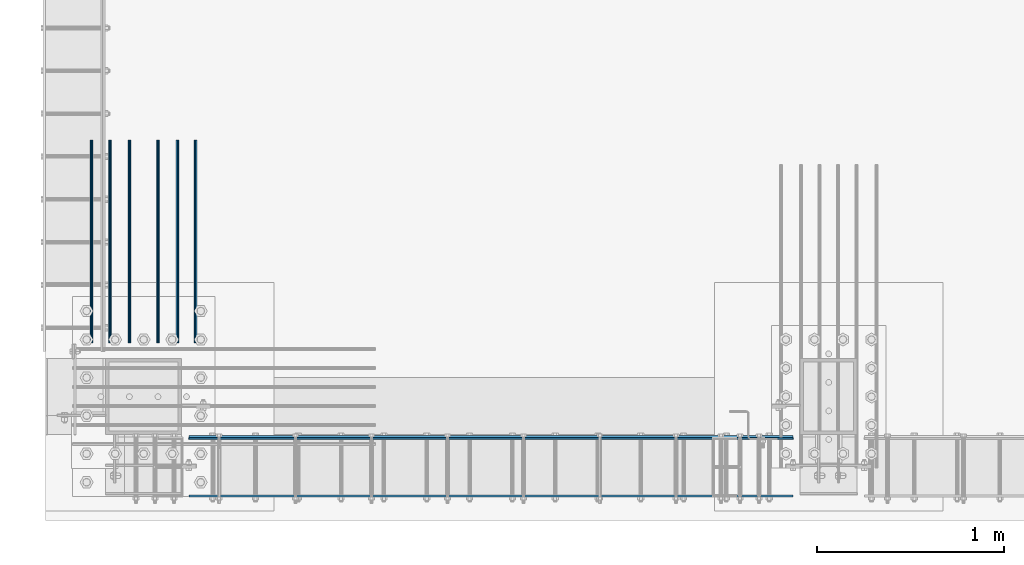
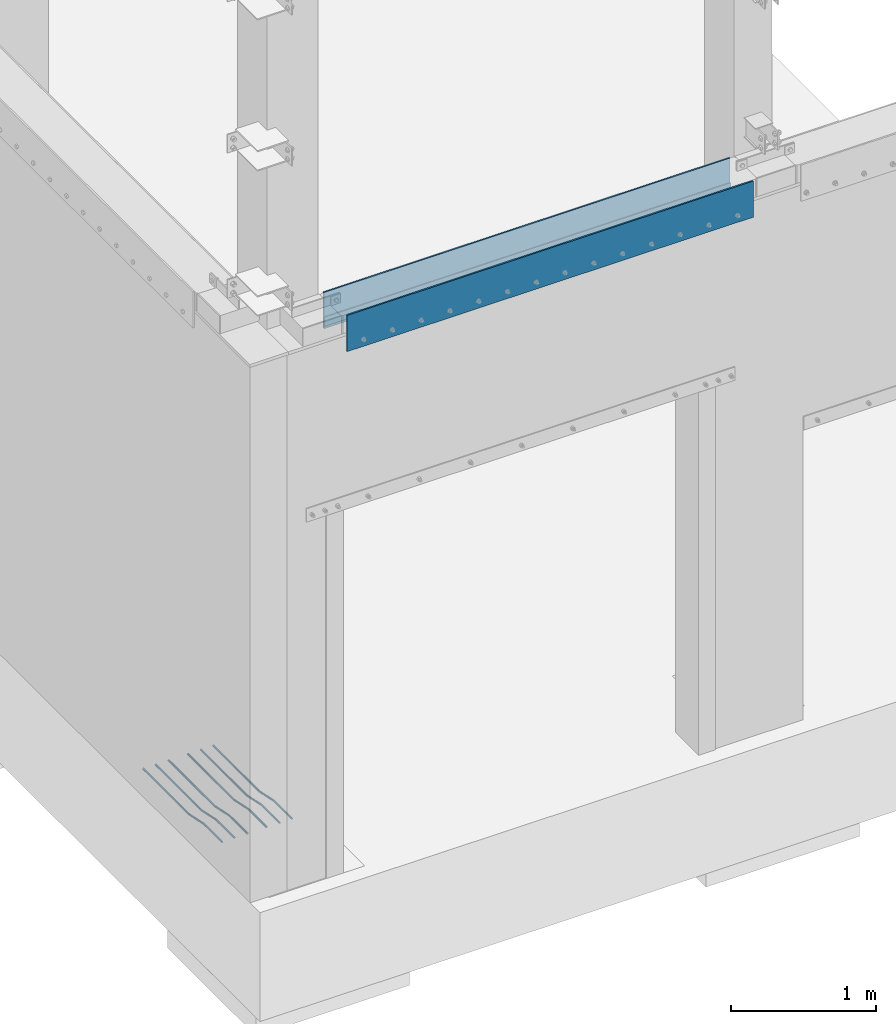
# One storey, part 907 of 1876: 9 beams, 3 elements without a shape of their own.
"""IFC2X3 building model written with IfcOpenShell, lengths in millimetres."""

from ifc_helpers import new_model, si_unit, frame, origin_with_axes, place, context, subcontext, project, spatial, faceted_brep, material, type_object, element, aggregate, save


model = new_model("IFC2X3")

# Units and contexts
model_context = context("Model", 3, precision=1e-05, world=origin_with_axes())
body_context = subcontext(model_context, "Body", "Model", "MODEL_VIEW")
ifc_project = project(units=[si_unit("LENGTHUNIT", "METRE", prefix="MILLI"), si_unit("AREAUNIT", "SQUARE_METRE"), si_unit("VOLUMEUNIT", "CUBIC_METRE"), si_unit("MASSUNIT", "GRAM", prefix="KILO"), si_unit("TIMEUNIT", "SECOND"), si_unit("PLANEANGLEUNIT", "RADIAN"), si_unit("SOLIDANGLEUNIT", "STERADIAN"), si_unit("THERMODYNAMICTEMPERATUREUNIT", "DEGREE_CELSIUS"), si_unit("LUMINOUSINTENSITYUNIT", "LUMEN")], contexts=[model_context])

# Site, building, storey
site_placement = place(None, origin_with_axes())
site = spatial("IfcSite", under=ifc_project, at=site_placement, CompositionType="ELEMENT")
building_placement = place(site_placement, origin_with_axes())
building = spatial("IfcBuilding", under=site, at=building_placement, Name="Undefined", CompositionType="ELEMENT")
storey_placement = place(building_placement, origin_with_axes())
storey = spatial("IfcBuildingStorey", under=building, at=storey_placement, Name="Undefined", CompositionType="ELEMENT", Elevation=0.0)

# Assembly, beam
assembly_1_placement = place(storey_placement, origin_with_axes())
assembly_1 = element("IfcElementAssembly", 1, at=assembly_1_placement, inside=storey, Name="PLATE", AssemblyPlace="NOTDEFINED", PredefinedType="RIGID_FRAME")
ifc_material_1 = material(Name="STEEL/A36")
beam_type_1 = type_object("IfcBeamType", PredefinedType="NOTDEFINED")
beam_1_placement = place(assembly_1_placement, frame((3698.87500038147, -25623.044, 4432.3), z_axis=(0.0, 0.0, 1.0), x_axis=(-1.0, 0.0, 0.0)))
beam_1 = element("IfcBeam", 2, at=beam_1_placement, type_object=beam_type_1, material=ifc_material_1, Name="PLATE", context=body_context, shape_type="Brep", body=[
    faceted_brep([(0.0, 3.969, -38.1000000000004), (0.0, 3.969, 38.1000000000004), (3225.80000076293, 3.969, 38.1000000000004), (3225.80000076293, 3.969, -38.1000000000004), (0.0, -3.969, 38.1000000000004), (3225.80000076293, -3.969, 38.1000000000004), (0.0, -3.969, -38.1000000000004), (3225.80000076293, -3.969, -38.1000000000004)], [[[0, 1, 2, 3]], [[1, 4, 5, 2]], [[4, 6, 7, 5]], [[6, 0, 3, 7]], [[5, 7, 3, 2]], [[6, 4, 1, 0]]]),
])

assembly_2_placement = place(storey_placement, origin_with_axes())
assembly_2 = element("IfcElementAssembly", 3, at=assembly_2_placement, inside=storey, Name="BEAM", AssemblyPlace="NOTDEFINED", PredefinedType="RIGID_FRAME")
beam_type_2 = type_object("IfcBeamType", PredefinedType="NOTDEFINED")
beam_2_placement = place(assembly_2_placement, frame((3698.875, -25930.225, 4521.2), z_axis=(0.0, 0.0, 1.0), x_axis=(-1.0, 0.0, 0.0)))
beam_2 = element("IfcBeam", 4, at=beam_2_placement, type_object=beam_type_2, material=ifc_material_1, Name="PLATE", context=body_context, shape_type="Brep", body=[
    faceted_brep([(0.0, 6.35000000000002, -152.4), (0.0, 6.35000000000002, 152.4), (3225.79999999999, 6.34999999999854, 152.4), (3225.79999999999, 6.34999999999854, -152.4), (0.0, -6.35000000000002, 152.4), (3225.79999999999, -6.34999999999854, 152.4), (0.0, -6.35000000000002, -152.4), (3225.79999999999, -6.34999999999854, -152.4)], [[[0, 1, 2, 3]], [[1, 4, 5, 2]], [[4, 6, 7, 5]], [[6, 0, 3, 7]], [[5, 7, 3, 2]], [[6, 4, 1, 0]]]),
])
aggregate(assembly_2, [beam_2])

# Beam
beam_3_placement = place(assembly_1_placement, frame((3698.875, -25612.725, 4521.2), z_axis=(0.0, 0.0, 1.0), x_axis=(-1.0, 0.0, 0.0)))
beam_3 = element("IfcBeam", 5, at=beam_3_placement, type_object=beam_type_2, material=ifc_material_1, Name="PLATE", context=body_context, shape_type="Brep", body=[
    faceted_brep([(0.0, 6.35000000000002, -152.4), (0.0, 6.35000000000002, 152.4), (3225.79999999999, 6.34999999999854, 152.4), (3225.79999999999, 6.34999999999854, -152.4), (0.0, -6.35000000000002, 152.4), (3225.79999999999, -6.34999999999854, 152.4), (0.0, -6.35000000000002, -152.4), (3225.79999999999, -6.34999999999854, -152.4)], [[[0, 1, 2, 3]], [[1, 4, 5, 2]], [[4, 6, 7, 5]], [[6, 0, 3, 7]], [[5, 7, 3, 2]], [[6, 4, 1, 0]]]),
])

aggregate(assembly_1, [beam_1, beam_3])

# Assembly, beams
assembly_3_placement = place(storey_placement, origin_with_axes())
assembly_3 = element("IfcElementAssembly", 6, at=assembly_3_placement, inside=storey, Name="PLATE", AssemblyPlace="NOTDEFINED", PredefinedType="RIGID_FRAME")
ifc_material_2 = material(Name="STEEL/A706-GR.60")
beam_type_3 = type_object("IfcBeamType", Name="5 REBAR", PredefinedType="NOTDEFINED")
beam_4_placement = place(assembly_3_placement, frame((-46.0375005657348, -25114.2499999925, -65.0875000000029), z_axis=(1.0, 0.0, 0.0), x_axis=(0.0, 1.0, 0.0)))
beam_4 = element("IfcBeam", 7, at=beam_4_placement, type_object=beam_type_3, material=ifc_material_2, Name="REBAR", ObjectType="5 REBAR", context=body_context, shape_type="Brep", body=[
    faceted_brep([(0.0, -7.9375, 0.0), (0.0, -5.61266007566822, -5.61266007566883), (246.321885275356, -5.61266007567184, -5.61266007566822), (246.321885275356, -7.93750000000362, 0.0), (0.0, 0.0, -7.9375), (246.321885275356, -3.62376795237651e-12, -7.9375), (0.0, 5.61266007566822, -5.61266007566883), (246.321885275356, 5.61266007566461, -5.61266007566822), (0.0, 7.9375, 0.0), (246.321885275356, 7.93749999999638, 0.0), (0.0, 5.61266007566822, 5.61266007566883), (246.321885275356, 5.6126600756646, 5.61266007566822), (0.0, 0.0, 7.9375), (246.321885275356, -3.62376795237651e-12, 7.9375), (0.0, -5.61266007566822, 5.61266007566883), (246.321885275356, -5.61266007567184, 5.61266007566822), (247.064414798144, -5.61266007567185, -5.61266007566822), (246.821885275356, -7.93750000000362, 0.0), (247.649932861328, -3.63797880709171e-12, -7.9375), (248.235450924512, 5.61266007566458, -5.61266007566822), (248.4779804473, 7.93749999999635, 0.0), (248.235450924512, 5.61266007566457, 5.61266007566822), (247.649932861328, -3.63797880709171e-12, 7.9375), (247.064414798144, -5.61266007567185, 5.61266007566822), (247.790956620502, -5.76591500240821, -5.61266007566822), (247.311119575181, -8.04069786758559, 0.0), (248.949385723045, -0.274103357843018, -7.9375), (250.107814825587, 5.21770828672217, -5.61266007566822), (250.587651870908, 7.49249115189956, 0.0), (250.107814825587, 5.21770828672217, 5.61266007566822), (248.949385723045, -0.274103357843018, 7.9375), (247.790956620502, -5.76591500240821, 5.61266007566822), (448.392032586522, -48.0802075237864, -5.61266007566822), (447.912195541201, -50.3549903889637, 0.0), (449.550461689065, -42.5883958792212, -7.9375), (450.708890791608, -37.096584234656, -5.61266007566822), (451.188727836929, -34.8218013694786, 0.0), (450.708890791608, -37.096584234656, 5.61266007566822), (449.550461689065, -42.5883958792212, 7.9375), (448.392032586522, -48.0802075237864, 5.61266007566822), (450.264396487597, -48.4751593127287, -5.61266007566822), (450.021866964809, -50.7999992370605, 0.0), (450.849914550781, -42.8624992370605, -7.9375), (451.435432613966, -37.2498391613923, -5.61266007566822), (451.677962136753, -34.9249992370605, 0.0), (451.435432613966, -37.2498391613923, 5.61266007566822), (450.849914550781, -42.8624992370605, 7.9375), (450.264396487597, -48.4751593127287, 5.61266007566822), (452.177962136753, -48.4751593127288, -5.61266007566822), (452.177962136753, -50.7999992370605, 0.0), (452.177962136753, -42.8624992370605, -7.9375), (452.177962136753, -37.2498391613923, -5.61266007566822), (452.177962136753, -34.9249992370605, 0.0), (452.177962136753, -37.2498391613923, 5.61266007566822), (452.177962136753, -42.8624992370605, 7.9375), (452.177962136753, -48.4751593127288, 5.61266007566822), (1085.84997558594, -48.4751593127288, -5.61266007566822), (1085.84997558594, -50.7999992370605, 0.0), (1085.84997558594, -42.8624992370605, -7.9375), (1085.84997558594, -37.2498391613923, -5.61266007566822), (1085.84997558594, -34.9249992370605, 0.0), (1085.84997558594, -37.2498391613923, 5.61266007566822), (1085.84997558594, -42.8624992370605, 7.9375), (1085.84997558594, -48.4751593127288, 5.61266007566822)], [[[0, 1, 2, 3]], [[1, 4, 5, 2]], [[4, 6, 7, 5]], [[6, 8, 9, 7]], [[8, 10, 11, 9]], [[10, 12, 13, 11]], [[12, 14, 15, 13]], [[14, 0, 3, 15]], [[14, 12, 10, 8, 6, 4, 1, 0]], [[3, 2, 16, 17]], [[2, 5, 18, 16]], [[5, 7, 19, 18]], [[7, 9, 20, 19]], [[9, 11, 21, 20]], [[11, 13, 22, 21]], [[13, 15, 23, 22]], [[15, 3, 17, 23]], [[17, 16, 24, 25]], [[16, 18, 26, 24]], [[18, 19, 27, 26]], [[19, 20, 28, 27]], [[20, 21, 29, 28]], [[21, 22, 30, 29]], [[22, 23, 31, 30]], [[23, 17, 25, 31]], [[25, 24, 32, 33]], [[24, 26, 34, 32]], [[26, 27, 35, 34]], [[27, 28, 36, 35]], [[28, 29, 37, 36]], [[29, 30, 38, 37]], [[30, 31, 39, 38]], [[31, 25, 33, 39]], [[33, 32, 40, 41]], [[32, 34, 42, 40]], [[34, 35, 43, 42]], [[35, 36, 44, 43]], [[36, 37, 45, 44]], [[37, 38, 46, 45]], [[38, 39, 47, 46]], [[39, 33, 41, 47]], [[41, 40, 48, 49]], [[40, 42, 50, 48]], [[42, 43, 51, 50]], [[43, 44, 52, 51]], [[44, 45, 53, 52]], [[45, 46, 54, 53]], [[46, 47, 55, 54]], [[47, 41, 49, 55]], [[49, 48, 56, 57]], [[48, 50, 58, 56]], [[50, 51, 59, 58]], [[51, 52, 60, 59]], [[52, 53, 61, 60]], [[53, 54, 62, 61]], [[54, 55, 63, 62]], [[55, 49, 57, 63]], [[58, 59, 60, 61, 62, 63, 57, 56]]]),
])
beam_5_placement = place(assembly_3_placement, frame((52.3874980626653, -25114.2499999925, -65.0874999999956), z_axis=(1.0, 0.0, 0.0), x_axis=(0.0, 1.0, 0.0)))
beam_5 = element("IfcBeam", 8, at=beam_5_placement, type_object=beam_type_3, material=ifc_material_2, Name="REBAR", ObjectType="5 REBAR", context=body_context, shape_type="Brep", body=[
    faceted_brep([(0.0, -7.9375, 0.0), (0.0, -5.61266007566822, -5.61266007566883), (246.321885275356, -5.61266007567184, -5.61266007566822), (246.321885275356, -7.93750000000362, 0.0), (0.0, 0.0, -7.9375), (246.321885275356, -3.62376795237651e-12, -7.9375), (0.0, 5.61266007566822, -5.61266007566883), (246.321885275356, 5.61266007566461, -5.61266007566822), (0.0, 7.9375, 0.0), (246.321885275356, 7.93749999999638, 0.0), (0.0, 5.61266007566822, 5.61266007566883), (246.321885275356, 5.6126600756646, 5.61266007566822), (0.0, 0.0, 7.9375), (246.321885275356, -3.62376795237651e-12, 7.9375), (0.0, -5.61266007566822, 5.61266007566883), (246.321885275356, -5.61266007567184, 5.61266007566822), (247.064414798144, -5.61266007567185, -5.61266007566822), (246.821885275356, -7.93750000000362, 0.0), (247.649932861328, -3.63797880709171e-12, -7.9375), (248.235450924512, 5.61266007566458, -5.61266007566822), (248.4779804473, 7.93749999999635, 0.0), (248.235450924512, 5.61266007566457, 5.61266007566822), (247.649932861328, -3.63797880709171e-12, 7.9375), (247.064414798144, -5.61266007567185, 5.61266007566822), (247.790956620502, -5.76591500240821, -5.61266007566822), (247.311119575181, -8.04069786758559, 0.0), (248.949385723045, -0.274103357843018, -7.9375), (250.107814825587, 5.21770828672217, -5.61266007566822), (250.587651870908, 7.49249115189956, 0.0), (250.107814825587, 5.21770828672217, 5.61266007566822), (248.949385723045, -0.274103357843018, 7.9375), (247.790956620502, -5.76591500240821, 5.61266007566822), (448.392032586522, -48.0802075237864, -5.61266007566822), (447.912195541201, -50.3549903889637, 0.0), (449.550461689065, -42.5883958792212, -7.9375), (450.708890791608, -37.096584234656, -5.61266007566822), (451.188727836929, -34.8218013694786, 0.0), (450.708890791608, -37.096584234656, 5.61266007566822), (449.550461689065, -42.5883958792212, 7.9375), (448.392032586522, -48.0802075237864, 5.61266007566822), (450.264396487597, -48.4751593127287, -5.61266007566822), (450.021866964809, -50.7999992370605, 0.0), (450.849914550781, -42.8624992370605, -7.9375), (451.435432613966, -37.2498391613923, -5.61266007566822), (451.677962136753, -34.9249992370605, 0.0), (451.435432613966, -37.2498391613923, 5.61266007566822), (450.849914550781, -42.8624992370605, 7.9375), (450.264396487597, -48.4751593127287, 5.61266007566822), (452.177962136753, -48.4751593127288, -5.61266007566822), (452.177962136753, -50.7999992370605, 0.0), (452.177962136753, -42.8624992370605, -7.9375), (452.177962136753, -37.2498391613923, -5.61266007566822), (452.177962136753, -34.9249992370605, 0.0), (452.177962136753, -37.2498391613923, 5.61266007566822), (452.177962136753, -42.8624992370605, 7.9375), (452.177962136753, -48.4751593127288, 5.61266007566822), (1085.84997558594, -48.4751593127288, -5.61266007566822), (1085.84997558594, -50.7999992370605, 0.0), (1085.84997558594, -42.8624992370605, -7.9375), (1085.84997558594, -37.2498391613923, -5.61266007566822), (1085.84997558594, -34.9249992370605, 0.0), (1085.84997558594, -37.2498391613923, 5.61266007566822), (1085.84997558594, -42.8624992370605, 7.9375), (1085.84997558594, -48.4751593127288, 5.61266007566822)], [[[0, 1, 2, 3]], [[1, 4, 5, 2]], [[4, 6, 7, 5]], [[6, 8, 9, 7]], [[8, 10, 11, 9]], [[10, 12, 13, 11]], [[12, 14, 15, 13]], [[14, 0, 3, 15]], [[14, 12, 10, 8, 6, 4, 1, 0]], [[3, 2, 16, 17]], [[2, 5, 18, 16]], [[5, 7, 19, 18]], [[7, 9, 20, 19]], [[9, 11, 21, 20]], [[11, 13, 22, 21]], [[13, 15, 23, 22]], [[15, 3, 17, 23]], [[17, 16, 24, 25]], [[16, 18, 26, 24]], [[18, 19, 27, 26]], [[19, 20, 28, 27]], [[20, 21, 29, 28]], [[21, 22, 30, 29]], [[22, 23, 31, 30]], [[23, 17, 25, 31]], [[25, 24, 32, 33]], [[24, 26, 34, 32]], [[26, 27, 35, 34]], [[27, 28, 36, 35]], [[28, 29, 37, 36]], [[29, 30, 38, 37]], [[30, 31, 39, 38]], [[31, 25, 33, 39]], [[33, 32, 40, 41]], [[32, 34, 42, 40]], [[34, 35, 43, 42]], [[35, 36, 44, 43]], [[36, 37, 45, 44]], [[37, 38, 46, 45]], [[38, 39, 47, 46]], [[39, 33, 41, 47]], [[41, 40, 48, 49]], [[40, 42, 50, 48]], [[42, 43, 51, 50]], [[43, 44, 52, 51]], [[44, 45, 53, 52]], [[45, 46, 54, 53]], [[46, 47, 55, 54]], [[47, 41, 49, 55]], [[49, 48, 56, 57]], [[48, 50, 58, 56]], [[50, 51, 59, 58]], [[51, 52, 60, 59]], [[52, 53, 61, 60]], [[53, 54, 62, 61]], [[54, 55, 63, 62]], [[55, 49, 57, 63]], [[58, 59, 60, 61, 62, 63, 57, 56]]]),
])
beam_6_placement = place(assembly_3_placement, frame((509.587499931718, -25114.2499999925, -65.0875000000029), z_axis=(1.0, 0.0, 0.0), x_axis=(0.0, 1.0, 0.0)))
beam_6 = element("IfcBeam", 9, at=beam_6_placement, type_object=beam_type_3, material=ifc_material_2, Name="REBAR", ObjectType="5 REBAR", context=body_context, shape_type="Brep", body=[
    faceted_brep([(0.0, -7.9375, 0.0), (0.0, -5.61266007566822, -5.61266007566883), (246.321885275356, -5.61266007567184, -5.61266007566822), (246.321885275356, -7.93750000000362, 0.0), (0.0, 0.0, -7.9375), (246.321885275356, -3.62376795237651e-12, -7.9375), (0.0, 5.61266007566822, -5.61266007566883), (246.321885275356, 5.61266007566461, -5.61266007566822), (0.0, 7.9375, 0.0), (246.321885275356, 7.93749999999638, 0.0), (0.0, 5.61266007566822, 5.61266007566883), (246.321885275356, 5.6126600756646, 5.61266007566822), (0.0, 0.0, 7.9375), (246.321885275356, -3.62376795237651e-12, 7.9375), (0.0, -5.61266007566822, 5.61266007566883), (246.321885275356, -5.61266007567184, 5.61266007566822), (247.064414798144, -5.61266007567185, -5.61266007566822), (246.821885275356, -7.93750000000362, 0.0), (247.649932861328, -3.63797880709171e-12, -7.9375), (248.235450924512, 5.61266007566458, -5.61266007566822), (248.4779804473, 7.93749999999635, 0.0), (248.235450924512, 5.61266007566457, 5.61266007566822), (247.649932861328, -3.63797880709171e-12, 7.9375), (247.064414798144, -5.61266007567185, 5.61266007566822), (247.790956620502, -5.76591500240821, -5.61266007566822), (247.311119575181, -8.04069786758559, 0.0), (248.949385723045, -0.274103357843018, -7.9375), (250.107814825587, 5.21770828672217, -5.61266007566822), (250.587651870908, 7.49249115189956, 0.0), (250.107814825587, 5.21770828672217, 5.61266007566822), (248.949385723045, -0.274103357843018, 7.9375), (247.790956620502, -5.76591500240821, 5.61266007566822), (448.392032586522, -48.0802075237864, -5.61266007566822), (447.912195541201, -50.3549903889637, 0.0), (449.550461689065, -42.5883958792212, -7.9375), (450.708890791608, -37.096584234656, -5.61266007566822), (451.188727836929, -34.8218013694786, 0.0), (450.708890791608, -37.096584234656, 5.61266007566822), (449.550461689065, -42.5883958792212, 7.9375), (448.392032586522, -48.0802075237864, 5.61266007566822), (450.264396487597, -48.4751593127287, -5.61266007566822), (450.021866964809, -50.7999992370605, 0.0), (450.849914550781, -42.8624992370605, -7.9375), (451.435432613966, -37.2498391613923, -5.61266007566822), (451.677962136753, -34.9249992370605, 0.0), (451.435432613966, -37.2498391613923, 5.61266007566822), (450.849914550781, -42.8624992370605, 7.9375), (450.264396487597, -48.4751593127287, 5.61266007566822), (452.177962136753, -48.4751593127288, -5.61266007566822), (452.177962136753, -50.7999992370605, 0.0), (452.177962136753, -42.8624992370605, -7.9375), (452.177962136753, -37.2498391613923, -5.61266007566822), (452.177962136753, -34.9249992370605, 0.0), (452.177962136753, -37.2498391613923, 5.61266007566822), (452.177962136753, -42.8624992370605, 7.9375), (452.177962136753, -48.4751593127288, 5.61266007566822), (1085.84997558594, -48.4751593127288, -5.61266007566822), (1085.84997558594, -50.7999992370605, 0.0), (1085.84997558594, -42.8624992370605, -7.9375), (1085.84997558594, -37.2498391613923, -5.61266007566822), (1085.84997558594, -34.9249992370605, 0.0), (1085.84997558594, -37.2498391613923, 5.61266007566822), (1085.84997558594, -42.8624992370605, 7.9375), (1085.84997558594, -48.4751593127288, 5.61266007566822)], [[[0, 1, 2, 3]], [[1, 4, 5, 2]], [[4, 6, 7, 5]], [[6, 8, 9, 7]], [[8, 10, 11, 9]], [[10, 12, 13, 11]], [[12, 14, 15, 13]], [[14, 0, 3, 15]], [[14, 12, 10, 8, 6, 4, 1, 0]], [[3, 2, 16, 17]], [[2, 5, 18, 16]], [[5, 7, 19, 18]], [[7, 9, 20, 19]], [[9, 11, 21, 20]], [[11, 13, 22, 21]], [[13, 15, 23, 22]], [[15, 3, 17, 23]], [[17, 16, 24, 25]], [[16, 18, 26, 24]], [[18, 19, 27, 26]], [[19, 20, 28, 27]], [[20, 21, 29, 28]], [[21, 22, 30, 29]], [[22, 23, 31, 30]], [[23, 17, 25, 31]], [[25, 24, 32, 33]], [[24, 26, 34, 32]], [[26, 27, 35, 34]], [[27, 28, 36, 35]], [[28, 29, 37, 36]], [[29, 30, 38, 37]], [[30, 31, 39, 38]], [[31, 25, 33, 39]], [[33, 32, 40, 41]], [[32, 34, 42, 40]], [[34, 35, 43, 42]], [[35, 36, 44, 43]], [[36, 37, 45, 44]], [[37, 38, 46, 45]], [[38, 39, 47, 46]], [[39, 33, 41, 47]], [[41, 40, 48, 49]], [[40, 42, 50, 48]], [[42, 43, 51, 50]], [[43, 44, 52, 51]], [[44, 45, 53, 52]], [[45, 46, 54, 53]], [[46, 47, 55, 54]], [[47, 41, 49, 55]], [[49, 48, 56, 57]], [[48, 50, 58, 56]], [[50, 51, 59, 58]], [[51, 52, 60, 59]], [[52, 53, 61, 60]], [[53, 54, 62, 61]], [[54, 55, 63, 62]], [[55, 49, 57, 63]], [[58, 59, 60, 61, 62, 63, 57, 56]]]),
])
beam_7_placement = place(assembly_3_placement, frame((411.162495628024, -25114.2499999925, -65.0875000000029), z_axis=(1.0, 0.0, 0.0), x_axis=(0.0, 1.0, 0.0)))
beam_7 = element("IfcBeam", 10, at=beam_7_placement, type_object=beam_type_3, material=ifc_material_2, Name="REBAR", ObjectType="5 REBAR", context=body_context, shape_type="Brep", body=[
    faceted_brep([(0.0, -7.9375, 0.0), (0.0, -5.61266007566822, -5.61266007566883), (246.321885275356, -5.61266007567184, -5.61266007566822), (246.321885275356, -7.93750000000362, 0.0), (0.0, 0.0, -7.9375), (246.321885275356, -3.62376795237651e-12, -7.9375), (0.0, 5.61266007566822, -5.61266007566883), (246.321885275356, 5.61266007566461, -5.61266007566822), (0.0, 7.9375, 0.0), (246.321885275356, 7.93749999999638, 0.0), (0.0, 5.61266007566822, 5.61266007566883), (246.321885275356, 5.6126600756646, 5.61266007566822), (0.0, 0.0, 7.9375), (246.321885275356, -3.62376795237651e-12, 7.9375), (0.0, -5.61266007566822, 5.61266007566883), (246.321885275356, -5.61266007567184, 5.61266007566822), (247.064414798144, -5.61266007567185, -5.61266007566822), (246.821885275356, -7.93750000000362, 0.0), (247.649932861328, -3.63797880709171e-12, -7.9375), (248.235450924512, 5.61266007566458, -5.61266007566822), (248.4779804473, 7.93749999999635, 0.0), (248.235450924512, 5.61266007566457, 5.61266007566822), (247.649932861328, -3.63797880709171e-12, 7.9375), (247.064414798144, -5.61266007567185, 5.61266007566822), (247.790956620502, -5.76591500240821, -5.61266007566822), (247.311119575181, -8.04069786758559, 0.0), (248.949385723045, -0.274103357843018, -7.9375), (250.107814825587, 5.21770828672217, -5.61266007566822), (250.587651870908, 7.49249115189956, 0.0), (250.107814825587, 5.21770828672217, 5.61266007566822), (248.949385723045, -0.274103357843018, 7.9375), (247.790956620502, -5.76591500240821, 5.61266007566822), (448.392032586522, -48.0802075237864, -5.61266007566822), (447.912195541201, -50.3549903889637, 0.0), (449.550461689065, -42.5883958792212, -7.9375), (450.708890791608, -37.096584234656, -5.61266007566822), (451.188727836929, -34.8218013694786, 0.0), (450.708890791608, -37.096584234656, 5.61266007566822), (449.550461689065, -42.5883958792212, 7.9375), (448.392032586522, -48.0802075237864, 5.61266007566822), (450.264396487597, -48.4751593127287, -5.61266007566822), (450.021866964809, -50.7999992370605, 0.0), (450.849914550781, -42.8624992370605, -7.9375), (451.435432613966, -37.2498391613923, -5.61266007566822), (451.677962136753, -34.9249992370605, 0.0), (451.435432613966, -37.2498391613923, 5.61266007566822), (450.849914550781, -42.8624992370605, 7.9375), (450.264396487597, -48.4751593127287, 5.61266007566822), (452.177962136753, -48.4751593127288, -5.61266007566822), (452.177962136753, -50.7999992370605, 0.0), (452.177962136753, -42.8624992370605, -7.9375), (452.177962136753, -37.2498391613923, -5.61266007566822), (452.177962136753, -34.9249992370605, 0.0), (452.177962136753, -37.2498391613923, 5.61266007566822), (452.177962136753, -42.8624992370605, 7.9375), (452.177962136753, -48.4751593127288, 5.61266007566822), (1085.84997558594, -48.4751593127288, -5.61266007566822), (1085.84997558594, -50.7999992370605, 0.0), (1085.84997558594, -42.8624992370605, -7.9375), (1085.84997558594, -37.2498391613923, -5.61266007566822), (1085.84997558594, -34.9249992370605, 0.0), (1085.84997558594, -37.2498391613923, 5.61266007566822), (1085.84997558594, -42.8624992370605, 7.9375), (1085.84997558594, -48.4751593127288, 5.61266007566822)], [[[0, 1, 2, 3]], [[1, 4, 5, 2]], [[4, 6, 7, 5]], [[6, 8, 9, 7]], [[8, 10, 11, 9]], [[10, 12, 13, 11]], [[12, 14, 15, 13]], [[14, 0, 3, 15]], [[14, 12, 10, 8, 6, 4, 1, 0]], [[3, 2, 16, 17]], [[2, 5, 18, 16]], [[5, 7, 19, 18]], [[7, 9, 20, 19]], [[9, 11, 21, 20]], [[11, 13, 22, 21]], [[13, 15, 23, 22]], [[15, 3, 17, 23]], [[17, 16, 24, 25]], [[16, 18, 26, 24]], [[18, 19, 27, 26]], [[19, 20, 28, 27]], [[20, 21, 29, 28]], [[21, 22, 30, 29]], [[22, 23, 31, 30]], [[23, 17, 25, 31]], [[25, 24, 32, 33]], [[24, 26, 34, 32]], [[26, 27, 35, 34]], [[27, 28, 36, 35]], [[28, 29, 37, 36]], [[29, 30, 38, 37]], [[30, 31, 39, 38]], [[31, 25, 33, 39]], [[33, 32, 40, 41]], [[32, 34, 42, 40]], [[34, 35, 43, 42]], [[35, 36, 44, 43]], [[36, 37, 45, 44]], [[37, 38, 46, 45]], [[38, 39, 47, 46]], [[39, 33, 41, 47]], [[41, 40, 48, 49]], [[40, 42, 50, 48]], [[42, 43, 51, 50]], [[43, 44, 52, 51]], [[44, 45, 53, 52]], [[45, 46, 54, 53]], [[46, 47, 55, 54]], [[47, 41, 49, 55]], [[49, 48, 56, 57]], [[48, 50, 58, 56]], [[50, 51, 59, 58]], [[51, 52, 60, 59]], [[52, 53, 61, 60]], [[53, 54, 62, 61]], [[54, 55, 63, 62]], [[55, 49, 57, 63]], [[58, 59, 60, 61, 62, 63, 57, 56]]]),
])
beam_8_placement = place(assembly_3_placement, frame((155.574998062665, -25114.2499999925, -65.0875000000029), z_axis=(1.0, 0.0, 0.0), x_axis=(0.0, 1.0, 0.0)))
beam_8 = element("IfcBeam", 11, at=beam_8_placement, type_object=beam_type_3, material=ifc_material_2, Name="REBAR", ObjectType="5 REBAR", context=body_context, shape_type="Brep", body=[
    faceted_brep([(0.0, -7.9375, 0.0), (0.0, -5.61266007566822, -5.61266007566883), (246.321885275356, -5.61266007567184, -5.61266007566822), (246.321885275356, -7.93750000000362, 0.0), (0.0, 0.0, -7.9375), (246.321885275356, -3.62376795237651e-12, -7.9375), (0.0, 5.61266007566822, -5.61266007566883), (246.321885275356, 5.61266007566461, -5.61266007566822), (0.0, 7.9375, 0.0), (246.321885275356, 7.93749999999638, 0.0), (0.0, 5.61266007566822, 5.61266007566883), (246.321885275356, 5.6126600756646, 5.61266007566822), (0.0, 0.0, 7.9375), (246.321885275356, -3.62376795237651e-12, 7.9375), (0.0, -5.61266007566822, 5.61266007566883), (246.321885275356, -5.61266007567184, 5.61266007566822), (247.064414798144, -5.61266007567185, -5.61266007566822), (246.821885275356, -7.93750000000362, 0.0), (247.649932861328, -3.63797880709171e-12, -7.9375), (248.235450924512, 5.61266007566458, -5.61266007566822), (248.4779804473, 7.93749999999635, 0.0), (248.235450924512, 5.61266007566457, 5.61266007566822), (247.649932861328, -3.63797880709171e-12, 7.9375), (247.064414798144, -5.61266007567185, 5.61266007566822), (247.790956620502, -5.76591500240821, -5.61266007566822), (247.311119575181, -8.04069786758559, 0.0), (248.949385723045, -0.274103357843018, -7.9375), (250.107814825587, 5.21770828672217, -5.61266007566822), (250.587651870908, 7.49249115189956, 0.0), (250.107814825587, 5.21770828672217, 5.61266007566822), (248.949385723045, -0.274103357843018, 7.9375), (247.790956620502, -5.76591500240821, 5.61266007566822), (448.392032586522, -48.0802075237864, -5.61266007566822), (447.912195541201, -50.3549903889637, 0.0), (449.550461689065, -42.5883958792212, -7.9375), (450.708890791608, -37.096584234656, -5.61266007566822), (451.188727836929, -34.8218013694786, 0.0), (450.708890791608, -37.096584234656, 5.61266007566822), (449.550461689065, -42.5883958792212, 7.9375), (448.392032586522, -48.0802075237864, 5.61266007566822), (450.264396487597, -48.4751593127287, -5.61266007566822), (450.021866964809, -50.7999992370605, 0.0), (450.849914550781, -42.8624992370605, -7.9375), (451.435432613966, -37.2498391613923, -5.61266007566822), (451.677962136753, -34.9249992370605, 0.0), (451.435432613966, -37.2498391613923, 5.61266007566822), (450.849914550781, -42.8624992370605, 7.9375), (450.264396487597, -48.4751593127287, 5.61266007566822), (452.177962136753, -48.4751593127288, -5.61266007566822), (452.177962136753, -50.7999992370605, 0.0), (452.177962136753, -42.8624992370605, -7.9375), (452.177962136753, -37.2498391613923, -5.61266007566822), (452.177962136753, -34.9249992370605, 0.0), (452.177962136753, -37.2498391613923, 5.61266007566822), (452.177962136753, -42.8624992370605, 7.9375), (452.177962136753, -48.4751593127288, 5.61266007566822), (1085.84997558594, -48.4751593127288, -5.61266007566822), (1085.84997558594, -50.7999992370605, 0.0), (1085.84997558594, -42.8624992370605, -7.9375), (1085.84997558594, -37.2498391613923, -5.61266007566822), (1085.84997558594, -34.9249992370605, 0.0), (1085.84997558594, -37.2498391613923, 5.61266007566822), (1085.84997558594, -42.8624992370605, 7.9375), (1085.84997558594, -48.4751593127288, 5.61266007566822)], [[[0, 1, 2, 3]], [[1, 4, 5, 2]], [[4, 6, 7, 5]], [[6, 8, 9, 7]], [[8, 10, 11, 9]], [[10, 12, 13, 11]], [[12, 14, 15, 13]], [[14, 0, 3, 15]], [[14, 12, 10, 8, 6, 4, 1, 0]], [[3, 2, 16, 17]], [[2, 5, 18, 16]], [[5, 7, 19, 18]], [[7, 9, 20, 19]], [[9, 11, 21, 20]], [[11, 13, 22, 21]], [[13, 15, 23, 22]], [[15, 3, 17, 23]], [[17, 16, 24, 25]], [[16, 18, 26, 24]], [[18, 19, 27, 26]], [[19, 20, 28, 27]], [[20, 21, 29, 28]], [[21, 22, 30, 29]], [[22, 23, 31, 30]], [[23, 17, 25, 31]], [[25, 24, 32, 33]], [[24, 26, 34, 32]], [[26, 27, 35, 34]], [[27, 28, 36, 35]], [[28, 29, 37, 36]], [[29, 30, 38, 37]], [[30, 31, 39, 38]], [[31, 25, 33, 39]], [[33, 32, 40, 41]], [[32, 34, 42, 40]], [[34, 35, 43, 42]], [[35, 36, 44, 43]], [[36, 37, 45, 44]], [[37, 38, 46, 45]], [[38, 39, 47, 46]], [[39, 33, 41, 47]], [[41, 40, 48, 49]], [[40, 42, 50, 48]], [[42, 43, 51, 50]], [[43, 44, 52, 51]], [[44, 45, 53, 52]], [[45, 46, 54, 53]], [[46, 47, 55, 54]], [[47, 41, 49, 55]], [[49, 48, 56, 57]], [[48, 50, 58, 56]], [[50, 51, 59, 58]], [[51, 52, 60, 59]], [[52, 53, 61, 60]], [[53, 54, 62, 61]], [[54, 55, 63, 62]], [[55, 49, 57, 63]], [[58, 59, 60, 61, 62, 63, 57, 56]]]),
])
beam_9_placement = place(assembly_3_placement, frame((307.974997779871, -25114.2499999925, -65.0875000000029), z_axis=(1.0, 0.0, 0.0), x_axis=(0.0, 1.0, 0.0)))
beam_9 = element("IfcBeam", 12, at=beam_9_placement, type_object=beam_type_3, material=ifc_material_2, Name="REBAR", ObjectType="5 REBAR", context=body_context, shape_type="Brep", body=[
    faceted_brep([(0.0, -7.9375, 0.0), (0.0, -5.61266007566822, -5.61266007566883), (246.321885275356, -5.61266007567184, -5.61266007566822), (246.321885275356, -7.93750000000362, 0.0), (0.0, 0.0, -7.9375), (246.321885275356, -3.62376795237651e-12, -7.9375), (0.0, 5.61266007566822, -5.61266007566883), (246.321885275356, 5.61266007566461, -5.61266007566822), (0.0, 7.9375, 0.0), (246.321885275356, 7.93749999999638, 0.0), (0.0, 5.61266007566822, 5.61266007566883), (246.321885275356, 5.6126600756646, 5.61266007566822), (0.0, 0.0, 7.9375), (246.321885275356, -3.62376795237651e-12, 7.9375), (0.0, -5.61266007566822, 5.61266007566883), (246.321885275356, -5.61266007567184, 5.61266007566822), (247.064414798144, -5.61266007567185, -5.61266007566822), (246.821885275356, -7.93750000000362, 0.0), (247.649932861328, -3.63797880709171e-12, -7.9375), (248.235450924512, 5.61266007566458, -5.61266007566822), (248.4779804473, 7.93749999999635, 0.0), (248.235450924512, 5.61266007566457, 5.61266007566822), (247.649932861328, -3.63797880709171e-12, 7.9375), (247.064414798144, -5.61266007567185, 5.61266007566822), (247.790956620502, -5.76591500240821, -5.61266007566822), (247.311119575181, -8.04069786758559, 0.0), (248.949385723045, -0.274103357843018, -7.9375), (250.107814825587, 5.21770828672217, -5.61266007566822), (250.587651870908, 7.49249115189956, 0.0), (250.107814825587, 5.21770828672217, 5.61266007566822), (248.949385723045, -0.274103357843018, 7.9375), (247.790956620502, -5.76591500240821, 5.61266007566822), (448.392032586522, -48.0802075237864, -5.61266007566822), (447.912195541201, -50.3549903889637, 0.0), (449.550461689065, -42.5883958792212, -7.9375), (450.708890791608, -37.096584234656, -5.61266007566822), (451.188727836929, -34.8218013694786, 0.0), (450.708890791608, -37.096584234656, 5.61266007566822), (449.550461689065, -42.5883958792212, 7.9375), (448.392032586522, -48.0802075237864, 5.61266007566822), (450.264396487597, -48.4751593127287, -5.61266007566822), (450.021866964809, -50.7999992370605, 0.0), (450.849914550781, -42.8624992370605, -7.9375), (451.435432613966, -37.2498391613923, -5.61266007566822), (451.677962136753, -34.9249992370605, 0.0), (451.435432613966, -37.2498391613923, 5.61266007566822), (450.849914550781, -42.8624992370605, 7.9375), (450.264396487597, -48.4751593127287, 5.61266007566822), (452.177962136753, -48.4751593127288, -5.61266007566822), (452.177962136753, -50.7999992370605, 0.0), (452.177962136753, -42.8624992370605, -7.9375), (452.177962136753, -37.2498391613923, -5.61266007566822), (452.177962136753, -34.9249992370605, 0.0), (452.177962136753, -37.2498391613923, 5.61266007566822), (452.177962136753, -42.8624992370605, 7.9375), (452.177962136753, -48.4751593127288, 5.61266007566822), (1085.84997558594, -48.4751593127288, -5.61266007566822), (1085.84997558594, -50.7999992370605, 0.0), (1085.84997558594, -42.8624992370605, -7.9375), (1085.84997558594, -37.2498391613923, -5.61266007566822), (1085.84997558594, -34.9249992370605, 0.0), (1085.84997558594, -37.2498391613923, 5.61266007566822), (1085.84997558594, -42.8624992370605, 7.9375), (1085.84997558594, -48.4751593127288, 5.61266007566822)], [[[0, 1, 2, 3]], [[1, 4, 5, 2]], [[4, 6, 7, 5]], [[6, 8, 9, 7]], [[8, 10, 11, 9]], [[10, 12, 13, 11]], [[12, 14, 15, 13]], [[14, 0, 3, 15]], [[14, 12, 10, 8, 6, 4, 1, 0]], [[3, 2, 16, 17]], [[2, 5, 18, 16]], [[5, 7, 19, 18]], [[7, 9, 20, 19]], [[9, 11, 21, 20]], [[11, 13, 22, 21]], [[13, 15, 23, 22]], [[15, 3, 17, 23]], [[17, 16, 24, 25]], [[16, 18, 26, 24]], [[18, 19, 27, 26]], [[19, 20, 28, 27]], [[20, 21, 29, 28]], [[21, 22, 30, 29]], [[22, 23, 31, 30]], [[23, 17, 25, 31]], [[25, 24, 32, 33]], [[24, 26, 34, 32]], [[26, 27, 35, 34]], [[27, 28, 36, 35]], [[28, 29, 37, 36]], [[29, 30, 38, 37]], [[30, 31, 39, 38]], [[31, 25, 33, 39]], [[33, 32, 40, 41]], [[32, 34, 42, 40]], [[34, 35, 43, 42]], [[35, 36, 44, 43]], [[36, 37, 45, 44]], [[37, 38, 46, 45]], [[38, 39, 47, 46]], [[39, 33, 41, 47]], [[41, 40, 48, 49]], [[40, 42, 50, 48]], [[42, 43, 51, 50]], [[43, 44, 52, 51]], [[44, 45, 53, 52]], [[45, 46, 54, 53]], [[46, 47, 55, 54]], [[47, 41, 49, 55]], [[49, 48, 56, 57]], [[48, 50, 58, 56]], [[50, 51, 59, 58]], [[51, 52, 60, 59]], [[52, 53, 61, 60]], [[53, 54, 62, 61]], [[54, 55, 63, 62]], [[55, 49, 57, 63]], [[58, 59, 60, 61, 62, 63, 57, 56]]]),
])
aggregate(assembly_3, [beam_4, beam_5, beam_6, beam_7, beam_8, beam_9])

save(model, "model.ifc")
